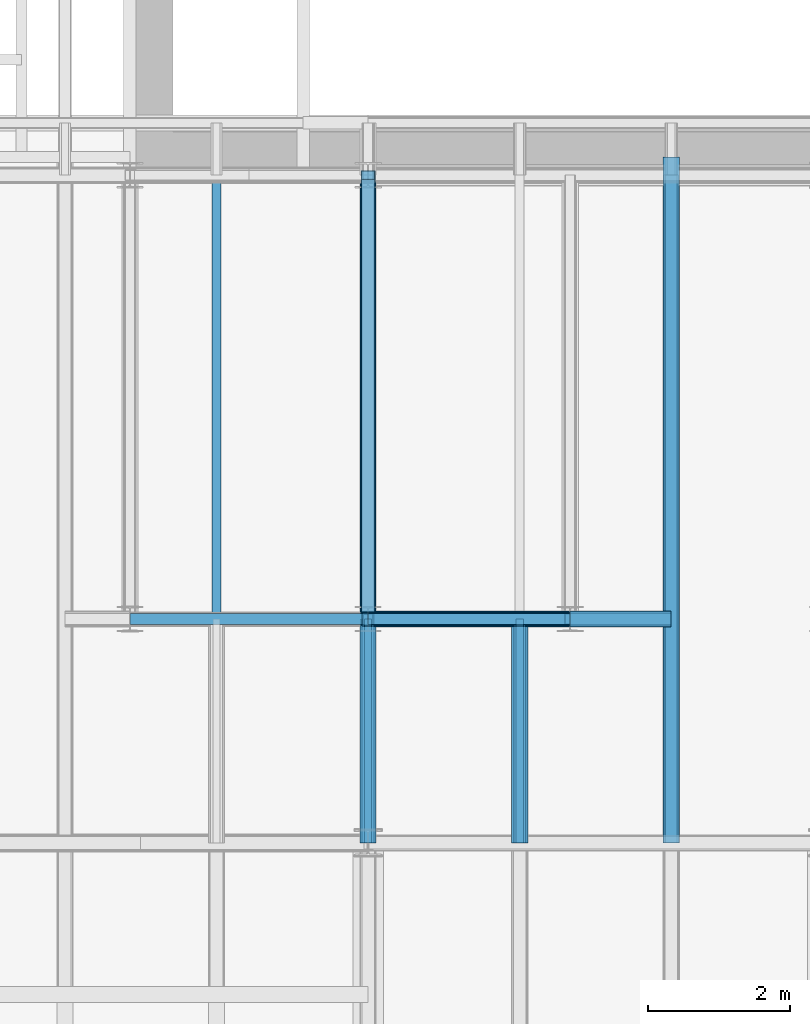
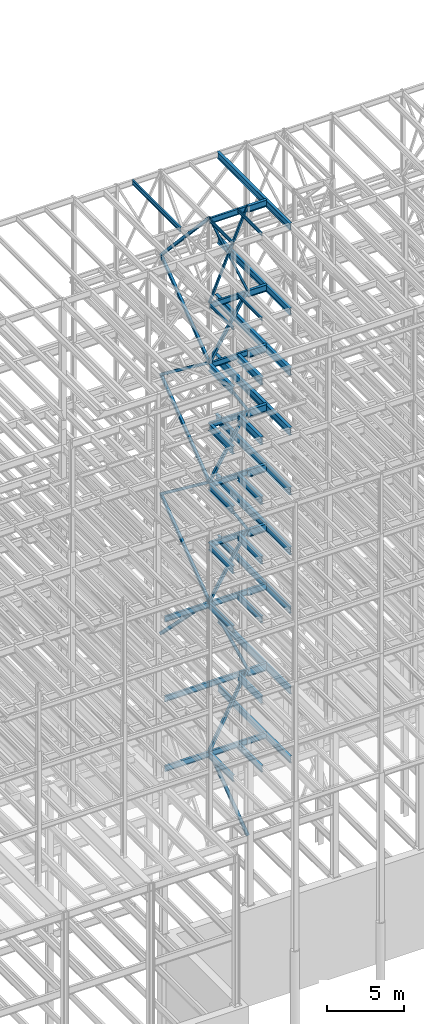
# One storey, part 134 of 150: 65 beams.
"""IFC2X3 building model written with IfcOpenShell, lengths in millimetres."""

import ifcopenshell
import ifcopenshell.guid

model = None  # the IFC model being written
_history = None  # IfcOwnerHistory: only IFC2X3 demands one
_inside = {}  # id of a spatial element -> (the spatial element, [elements in it])
_under = {}  # id of a project, library or spatial element -> (it, [spatial elements below it])
_declared = {}  # id of a project -> (the project, [libraries it declares])
_typed = {}  # id of a type object -> (the type object, [elements of that type])
_made_of = {}  # id of a material, layer set ... -> (it, [elements and type objects made of it])


def new_model(schema):
    """Start an empty IFC model of exactly this schema.

    Asked for "IFC4X3", IfcOpenShell would pick the latest addendum, in which some entities
    have other attributes; the version numbers below select the first issue.
    IFC2X3 requires an IfcOwnerHistory on every rooted entity: one is made here for all.
    """
    global model, _history
    if schema == "IFC4X3":
        model = ifcopenshell.file(schema_version=(4, 3, 0, 0))
    else:
        model = ifcopenshell.file(schema=schema)
    _inside.clear()
    _under.clear()
    _declared.clear()
    _typed.clear()
    _made_of.clear()
    _history = None
    if model.schema == "IFC2X3":
        org = make("IfcOrganization", Name="unknown")
        user = make(
            "IfcPersonAndOrganization",
            ThePerson=make("IfcPerson", FamilyName="unknown"),
            TheOrganization=org,
        )
        app = make(
            "IfcApplication",
            ApplicationDeveloper=org,
            Version="unknown",
            ApplicationFullName="unknown",
            ApplicationIdentifier="unknown",
        )
        _history = make(
            "IfcOwnerHistory",
            OwningUser=user,
            OwningApplication=app,
            ChangeAction="ADDED",
            CreationDate=0,
        )
    return model


def make(cls, **values):
    """One entity of the class cls with the attributes given. An attribute that is None is left unset."""
    return model.create_entity(
        cls, **{name: value for name, value in values.items() if value is not None}
    )


def rooted(cls, **values):
    """An entity with a GlobalId (a new one), such as an element, a storey or a relation."""
    return make(cls, GlobalId=ifcopenshell.guid.new(), OwnerHistory=_history, **values)


def si_unit(unit_type, name, prefix=None):
    """IfcSIUnit, for example si_unit("LENGTHUNIT", "METRE", prefix="MILLI")."""
    return make("IfcSIUnit", UnitType=unit_type, Prefix=prefix, Name=name)


def assignment(units):
    """IfcUnitAssignment: the units of a project."""
    return None if units is None else make("IfcUnitAssignment", Units=units)


def point(xyz):
    """IfcCartesianPoint."""
    return None if xyz is None else make("IfcCartesianPoint", Coordinates=xyz)


def direction(xyz):
    """IfcDirection."""
    return None if xyz is None else make("IfcDirection", DirectionRatios=xyz)


def frame(location, z_axis=None, x_axis=None):
    """IfcAxis2Placement3D, a coordinate frame: its origin and axes. An axis left out is left unset."""
    return make(
        "IfcAxis2Placement3D",
        Location=point(location),
        Axis=direction(z_axis),
        RefDirection=direction(x_axis),
    )


def frame_2d(location, x_axis=None):
    """IfcAxis2Placement2D, a coordinate frame in the plane: its origin and x axis."""
    return make(
        "IfcAxis2Placement2D", Location=point(location), RefDirection=direction(x_axis)
    )


def origin_with_axes():
    """The frame at (0, 0, 0) with the z axis (0, 0, 1) and the x axis (1, 0, 0) written out."""
    return frame((0.0, 0.0, 0.0), z_axis=(0.0, 0.0, 1.0), x_axis=(1.0, 0.0, 0.0))


def origin_2d_with_axis():
    """The frame at (0, 0) in the plane with the x axis (1, 0) written out."""
    return frame_2d((0.0, 0.0), x_axis=(1.0, 0.0))


def place(relative_to, where):
    """IfcLocalPlacement: puts the frame where relative to a parent placement (None: the world)."""
    return make(
        "IfcLocalPlacement", PlacementRelTo=relative_to, RelativePlacement=where
    )


def context(
    kind, dimensions, precision=None, world=None, true_north=None, identifier=None
):
    """IfcGeometricRepresentationContext, for example the 3D "Model" context."""
    return make(
        "IfcGeometricRepresentationContext",
        ContextIdentifier=identifier,
        ContextType=kind,
        CoordinateSpaceDimension=dimensions,
        Precision=precision,
        WorldCoordinateSystem=world,
        TrueNorth=true_north,
    )


def subcontext(parent, identifier, kind, view, scale=None):
    """IfcGeometricRepresentationSubContext, for example "Body" below "Model"."""
    return make(
        "IfcGeometricRepresentationSubContext",
        ContextIdentifier=identifier,
        ContextType=kind,
        ParentContext=parent,
        TargetScale=scale,
        TargetView=view,
    )


def project(units=None, contexts=None):
    """IfcProject with its units and contexts."""
    return rooted(
        "IfcProject",
        Name="project",
        RepresentationContexts=contexts,
        UnitsInContext=assignment(units),
    )


def spatial(cls, under=None, at=None, **own):
    """A site, building, storey or space (cls), placed at a placement, below another one or the project."""
    s = rooted(cls, ObjectPlacement=at, **own)
    if under is not None:
        _under.setdefault(under.id(), (under, []))[1].append(s)
    return s


def profile(cls, at=None, kind="AREA", **sizes):
    """A parametric profile (cls). Its sizes go by their IFC names, for example OverallWidth=200.0."""
    return make(cls, ProfileType=kind, Position=at, **sizes)


def hollow_rectangle(**sizes):
    """IfcRectangleHollowProfileDef."""
    return profile("IfcRectangleHollowProfileDef", **sizes)


def i_section(**sizes):
    """IfcIShapeProfileDef."""
    return profile("IfcIShapeProfileDef", **sizes)


def extrude(swept, where, along, depth):
    """IfcExtrudedAreaSolid: the profile swept, set in the frame where, extruded along a direction by depth."""
    return make(
        "IfcExtrudedAreaSolid",
        SweptArea=swept,
        Position=where,
        ExtrudedDirection=direction(along),
        Depth=depth,
    )


def shape(context_of_items, identifier, shape_type, items):
    """IfcShapeRepresentation: the items that make up one representation, for example the "Body"."""
    return make(
        "IfcShapeRepresentation",
        ContextOfItems=context_of_items,
        RepresentationIdentifier=identifier,
        RepresentationType=shape_type,
        Items=items,
    )


def material(Name=None, Category=None):
    """IfcMaterial."""
    return make("IfcMaterial", Name=Name, Category=Category)


def made_of(thing, what):
    """Note that an element or type object is made of a material, layer set ...; save() writes the relation."""
    if what is not None:
        _made_of.setdefault(what.id(), (what, []))[1].append(thing)
    return thing


def type_object(cls, material=None, **own):
    """A type object (cls), such as IfcWallType, which elements share."""
    return made_of(rooted(cls, **own), material)


def element(
    cls,
    number,
    at=None,
    inside=None,
    cuts=None,
    type_object=None,
    material=None,
    context=None,
    identifier="Body",
    shape_type=None,
    held_by="IfcProductDefinitionShape",
    body=None,
    shapes=None,
    **own,
):
    """One element of the class cls, such as IfcWall. Its Tag is "e" and its number.

    at: its placement. inside: the storey or other place that contains it. cuts: it is an
    opening in that element (IfcRelVoidsElement). A single representation is given by context,
    identifier, shape_type and body (its items); several are given by shapes. held_by: the class
    of the entity that holds the representations. save() writes the other relations.
    """
    e = rooted(cls, Tag="e%d" % number, ObjectPlacement=at, **own)
    if body is not None:
        shapes = [shape(context, identifier, shape_type, body)]
    if shapes is not None:
        e.Representation = make(held_by, Representations=shapes)
    if inside is not None:
        _inside.setdefault(inside.id(), (inside, []))[1].append(e)
    if cuts is not None:
        rooted(
            "IfcRelVoidsElement", RelatingBuildingElement=cuts, RelatedOpeningElement=e
        )
    if type_object is not None:
        _typed.setdefault(type_object.id(), (type_object, []))[1].append(e)
    return made_of(e, material)


def aggregate(whole, parts):
    """IfcRelAggregates: a whole, such as a stair, and the parts it consists of."""
    return rooted("IfcRelAggregates", RelatingObject=whole, RelatedObjects=parts)


def save(model, path):
    """Write the relations noted so far, then the file.

    IfcRelAggregates (storeys below a building ...), IfcRelContainedInSpatialStructure (elements
    in a storey), IfcRelDefinesByType, IfcRelAssociatesMaterial and IfcRelDeclares: one each for
    every whole, place, type object, material and project.
    """
    for whole, parts in _under.values():
        aggregate(whole, parts)
    for where, things in _inside.values():
        rooted(
            "IfcRelContainedInSpatialStructure",
            RelatedElements=things,
            RelatingStructure=where,
        )
    for kind, things in _typed.values():
        rooted("IfcRelDefinesByType", RelatedObjects=things, RelatingType=kind)
    for what, things in _made_of.values():
        rooted("IfcRelAssociatesMaterial", RelatedObjects=things, RelatingMaterial=what)
    for by, libraries in _declared.values():
        rooted("IfcRelDeclares", RelatingContext=by, RelatedDefinitions=libraries)
    model.write(path)


model = new_model("IFC2X3")

# Units and contexts
model_context = context("Model", 3, precision=1e-05, world=origin_with_axes())
body_context = subcontext(model_context, "Body", "Model", "MODEL_VIEW")
ifc_project = project(units=[si_unit("LENGTHUNIT", "METRE", prefix="MILLI"), si_unit("AREAUNIT", "SQUARE_METRE"), si_unit("VOLUMEUNIT", "CUBIC_METRE"), si_unit("MASSUNIT", "GRAM", prefix="KILO"), si_unit("TIMEUNIT", "SECOND"), si_unit("PLANEANGLEUNIT", "RADIAN"), si_unit("SOLIDANGLEUNIT", "STERADIAN"), si_unit("THERMODYNAMICTEMPERATUREUNIT", "DEGREE_CELSIUS"), si_unit("LUMINOUSINTENSITYUNIT", "LUMEN")], contexts=[model_context])

# Site, building, storey
site_placement = place(None, origin_with_axes())
site = spatial("IfcSite", under=ifc_project, at=site_placement, CompositionType="ELEMENT")
building_placement = place(site_placement, origin_with_axes())
building = spatial("IfcBuilding", under=site, at=building_placement, Name="Undefined", CompositionType="ELEMENT")
storey_placement = place(building_placement, origin_with_axes())
storey = spatial("IfcBuildingStorey", under=building, at=storey_placement, Name="Undefined", CompositionType="ELEMENT", Elevation=0.0)

# Beams
ifc_material_1 = material()
beam_type_1 = type_object("IfcBeamType", Name="HSS8X8X3/8", PredefinedType="NOTDEFINED")
beam_1_placement = place(storey_placement, frame((56591.2, 25628.6, 45034.2), z_axis=(0.0, -0.603108242282795, 0.797659355922412), x_axis=(0.0, 0.797659355922412, 0.603108242282795)))
element("IfcBeam", 1, at=beam_1_placement, inside=storey, type_object=beam_type_1, material=ifc_material_1, Name="BEAM", ObjectType="HSS8X8X3/8", context=body_context, shape_type="SweptSolid", body=[
    extrude(hollow_rectangle(XDim=203.2, YDim=203.2, WallThickness=9.525, InnerFilletRadius=9.5249, OuterFilletRadius=19.0499, at=origin_2d_with_axis()), frame((7833.4188347737, 0.0, -8.69684195189813e-13), z_axis=(-1.0, 0.0, 0.0), x_axis=(0.0, -1.0, 0.0)), (0.0, 0.0, 1.0), 7833.4188347737),
])
beam_2_placement = place(storey_placement, frame((56591.2, 31877.0, 40309.8), z_axis=(0.0, 0.603108242282795, 0.797659355922412), x_axis=(0.0, -0.797659355922412, 0.603108242282795)))
element("IfcBeam", 2, at=beam_2_placement, inside=storey, type_object=beam_type_1, material=ifc_material_1, Name="BEAM", ObjectType="HSS8X8X3/8", context=body_context, shape_type="SweptSolid", body=[
    extrude(hollow_rectangle(XDim=203.2, YDim=203.2, WallThickness=9.525, InnerFilletRadius=9.5249, OuterFilletRadius=19.0499, at=origin_2d_with_axis()), frame((7833.41960403484, 0.0, 0.0), z_axis=(-1.0, 0.0, 0.0), x_axis=(0.0, -1.0, 0.0)), (0.0, 0.0, 1.0), 7833.41960403484),
])
beam_3_placement = place(storey_placement, frame((56591.2, 25628.6, 35585.4), z_axis=(0.0, -0.603108242282795, 0.797659355922412), x_axis=(0.0, 0.797659355922412, 0.603108242282795)))
element("IfcBeam", 3, at=beam_3_placement, inside=storey, type_object=beam_type_1, material=ifc_material_1, Name="BEAM", ObjectType="HSS8X8X3/8", context=body_context, shape_type="SweptSolid", body=[
    extrude(hollow_rectangle(XDim=203.2, YDim=203.2, WallThickness=9.525, InnerFilletRadius=9.5249, OuterFilletRadius=19.0499, at=origin_2d_with_axis()), frame((7833.4188347737, 0.0, -8.69684195189813e-13), z_axis=(-1.0, 0.0, 0.0), x_axis=(0.0, -1.0, 0.0)), (0.0, 0.0, 1.0), 7833.41883477371),
])
beam_4_placement = place(storey_placement, frame((56591.2, 25628.6, 54483.0), z_axis=(-0.856679076231124, 0.0, 0.515849745902611), x_axis=(0.51584974590261, 0.0, 0.856679076231124)))
element("IfcBeam", 4, at=beam_4_placement, inside=storey, type_object=beam_type_1, material=ifc_material_1, Name="BEAM", ObjectType="HSS8X8X3/8", context=body_context, shape_type="SweptSolid", body=[
    extrude(hollow_rectangle(XDim=203.2, YDim=203.2, WallThickness=9.525, InnerFilletRadius=9.5249, OuterFilletRadius=19.0499, at=origin_2d_with_axis()), frame((5514.78398489006, -3.63797880709171e-12, 0.0), z_axis=(-1.0, 0.0, 0.0), x_axis=(0.0, -1.0, 0.0)), (0.0, 0.0, 1.0), 5514.78398489007),
])
beam_5_placement = place(storey_placement, frame((59435.9996641932, 25628.6, 49758.5996294296), z_axis=(0.856679076231126, 0.0, 0.515849745902608), x_axis=(-0.515849745902611, 0.0, 0.856679076231124)))
element("IfcBeam", 5, at=beam_5_placement, inside=storey, type_object=beam_type_1, material=ifc_material_1, Name="BEAM", ObjectType="HSS8X8X3/8", context=body_context, shape_type="SweptSolid", body=[
    extrude(hollow_rectangle(XDim=203.2, YDim=203.2, WallThickness=9.525, InnerFilletRadius=9.5249, OuterFilletRadius=19.0499, at=origin_2d_with_axis()), frame((5514.78412912414, -3.63797880709171e-12, 0.0), z_axis=(-1.0, 0.0, 0.0), x_axis=(0.0, -1.0, 0.0)), (0.0, 0.0, 1.0), 5514.78412912414),
])
beam_6_placement = place(storey_placement, frame((56591.2, 25628.6, 45034.2), z_axis=(-0.856679076231124, 0.0, 0.515849745902611), x_axis=(0.51584974590261, 0.0, 0.856679076231124)))
element("IfcBeam", 6, at=beam_6_placement, inside=storey, type_object=beam_type_1, material=ifc_material_1, Name="BEAM", ObjectType="HSS8X8X3/8", context=body_context, shape_type="SweptSolid", body=[
    extrude(hollow_rectangle(XDim=203.2, YDim=203.2, WallThickness=9.525, InnerFilletRadius=9.5249, OuterFilletRadius=19.0499, at=origin_2d_with_axis()), frame((5514.78398489006, -3.63797880709171e-12, 0.0), z_axis=(-1.0, 0.0, 0.0), x_axis=(0.0, -1.0, 0.0)), (0.0, 0.0, 1.0), 5514.78398489008),
])
beam_7_placement = place(storey_placement, frame((59435.9996641932, 25628.6, 40309.7996294296), z_axis=(0.856679076231126, 0.0, 0.515849745902608), x_axis=(-0.515849745902611, 0.0, 0.856679076231124)))
element("IfcBeam", 7, at=beam_7_placement, inside=storey, type_object=beam_type_1, material=ifc_material_1, Name="BEAM", ObjectType="HSS8X8X3/8", context=body_context, shape_type="SweptSolid", body=[
    extrude(hollow_rectangle(XDim=203.2, YDim=203.2, WallThickness=9.525, InnerFilletRadius=9.5249, OuterFilletRadius=19.0499, at=origin_2d_with_axis()), frame((5514.78412912414, -3.63797880709171e-12, 0.0), z_axis=(-1.0, 0.0, 0.0), x_axis=(0.0, -1.0, 0.0)), (0.0, 0.0, 1.0), 5514.78412912414),
])
beam_8_placement = place(storey_placement, frame((56591.2, 25628.6, 35585.4), z_axis=(-0.856679076231124, 0.0, 0.515849745902611), x_axis=(0.51584974590261, 0.0, 0.856679076231124)))
element("IfcBeam", 8, at=beam_8_placement, inside=storey, type_object=beam_type_1, material=ifc_material_1, Name="BEAM", ObjectType="HSS8X8X3/8", context=body_context, shape_type="SweptSolid", body=[
    extrude(hollow_rectangle(XDim=203.2, YDim=203.2, WallThickness=9.525, InnerFilletRadius=9.5249, OuterFilletRadius=19.0499, at=origin_2d_with_axis()), frame((5514.78398489006, -3.63797880709171e-12, 0.0), z_axis=(-1.0, 0.0, 0.0), x_axis=(0.0, -1.0, 0.0)), (0.0, 0.0, 1.0), 5514.78398489007),
])
beam_9_placement = place(storey_placement, frame((59435.9998773698, 25628.6, 29286.1996461044), z_axis=(0.911370591188493, 0.0, 0.4115867411819), x_axis=(-0.411586741181902, 0.0, 0.911370591188492)))
element("IfcBeam", 9, at=beam_9_placement, inside=storey, type_object=beam_type_1, material=ifc_material_1, Name="BEAM", ObjectType="HSS8X8X3/8", context=body_context, shape_type="SweptSolid", body=[
    extrude(hollow_rectangle(XDim=203.2, YDim=203.2, WallThickness=9.525, InnerFilletRadius=9.5249, OuterFilletRadius=19.0499, at=origin_2d_with_axis()), frame((6911.78786138591, 0.0, 3.83681301251766e-13), z_axis=(-1.0, 0.0, 0.0), x_axis=(0.0, -1.0, 0.0)), (0.0, 0.0, 1.0), 6911.78786138592),
])
beam_10_placement = place(storey_placement, frame((56591.2, 25628.6, 23774.4), z_axis=(-0.88862065311074, 0.0, 0.458642927411993), x_axis=(0.458642927411995, 0.0, 0.888620653110738)))
element("IfcBeam", 10, at=beam_10_placement, inside=storey, type_object=beam_type_1, material=ifc_material_1, Name="BEAM", ObjectType="HSS8X8X3/8", context=body_context, shape_type="SweptSolid", body=[
    extrude(hollow_rectangle(XDim=203.2, YDim=203.2, WallThickness=9.525, InnerFilletRadius=9.5249, OuterFilletRadius=19.0499, at=origin_2d_with_axis()), frame((6202.64671571741, 3.63797880709171e-12, 7.27595761418343e-12), z_axis=(-1.0, 0.0, 0.0), x_axis=(0.0, -1.0, 0.0)), (0.0, 0.0, 1.0), 6202.64671571741),
])
ifc_material_2 = material(Name="STEEL/A992")
beam_type_2 = type_object("IfcBeamType", Name="W18X35", PredefinedType="NOTDEFINED")
for number, where, z_axis, x_axis, name in (
    (11, (56591.2, 25628.6, 65687.575), (0.0, 0.0, 1.0), (1.0, 0.0, 0.0), "BEAM"),
    (12, (56591.2, 25628.6, 58981.975), (0.0, 0.0, 1.0), (1.0, 0.0, 0.0), "BEAM"),
    (13, (56591.2, 25628.6, 54257.575), (0.0, 0.0, 1.0), (1.0, 0.0, 0.0), "BEAM"),
    (14, (56591.2, 25628.6, 49533.175), (0.0, 0.0, 1.0), (1.0, 0.0, 0.0), "BEAM"),
    (15, (56591.2, 25628.6, 44808.775), (0.0, 0.0, 1.0), (1.0, 0.0, 0.0), "BEAM"),
    (16, (56591.2, 25628.6, 40084.375), (0.0, 0.0, 1.0), (1.0, 0.0, 0.0), "BEAM"),
    (17, (56591.2, 25628.6, 35359.975), (0.0, 0.0, 1.0), (1.0, 0.0, 0.0), "BEAM"),
):
    element("IfcBeam", number, at=place(storey_placement, frame(where, z_axis=z_axis, x_axis=x_axis)), inside=storey, type_object=beam_type_2, material=ifc_material_2, Name=name, ObjectType="W18X35", context=body_context, shape_type="SweptSolid", body=[
        extrude(i_section(OverallWidth=152.4, OverallDepth=450.85, WebThickness=7.9375, FlangeThickness=10.795, FilletRadius=17.78, at=origin_2d_with_axis()), frame((2844.8, 0.0, 0.0), z_axis=(-1.0, 0.0, 0.0), x_axis=(0.0, -1.0, 0.0)), (0.0, 0.0, 1.0), 2844.8),
    ])
beam_11_placement = place(storey_placement, frame((53238.4, 25628.6, 35359.975), z_axis=(0.0, 0.0, 1.0), x_axis=(1.0, 0.0, 0.0)))
element("IfcBeam", 18, at=beam_11_placement, inside=storey, type_object=beam_type_2, material=ifc_material_2, Name="BEAM", ObjectType="W18X35", context=body_context, shape_type="SweptSolid", body=[
    extrude(i_section(OverallWidth=152.4, OverallDepth=450.85, WebThickness=7.9375, FlangeThickness=10.795, FilletRadius=17.78, at=origin_2d_with_axis()), frame((3352.8, 0.0, 0.0), z_axis=(-1.0, 0.0, 0.0), x_axis=(0.0, -1.0, 0.0)), (0.0, 0.0, 1.0), 3352.8),
])
beam_12_placement = place(storey_placement, frame((56591.2, 25628.6, 29060.775), z_axis=(0.0, 0.0, 1.0), x_axis=(1.0, 0.0, 0.0)))
element("IfcBeam", 19, at=beam_12_placement, inside=storey, type_object=beam_type_2, material=ifc_material_2, Name="BEAM", ObjectType="W18X35", context=body_context, shape_type="SweptSolid", body=[
    extrude(i_section(OverallWidth=152.4, OverallDepth=450.85, WebThickness=7.9375, FlangeThickness=10.795, FilletRadius=17.78, at=origin_2d_with_axis()), frame((2844.8, 0.0, 0.0), z_axis=(-1.0, 0.0, 0.0), x_axis=(0.0, -1.0, 0.0)), (0.0, 0.0, 1.0), 2844.8),
])
beam_13_placement = place(storey_placement, frame((53238.4, 25628.6, 29060.775), z_axis=(0.0, 0.0, 1.0), x_axis=(1.0, 0.0, 0.0)))
element("IfcBeam", 20, at=beam_13_placement, inside=storey, type_object=beam_type_2, material=ifc_material_2, Name="BEAM", ObjectType="W18X35", context=body_context, shape_type="SweptSolid", body=[
    extrude(i_section(OverallWidth=152.4, OverallDepth=450.85, WebThickness=7.9375, FlangeThickness=10.795, FilletRadius=17.78, at=origin_2d_with_axis()), frame((3352.8, 0.0, 0.0), z_axis=(-1.0, 0.0, 0.0), x_axis=(0.0, -1.0, 0.0)), (0.0, 0.0, 1.0), 3352.8),
])
beam_14_placement = place(storey_placement, frame((59436.0, 25628.6, 23548.975), z_axis=(0.0, 0.0, 1.0), x_axis=(1.0, 0.0, 0.0)))
element("IfcBeam", 21, at=beam_14_placement, inside=storey, type_object=beam_type_2, material=ifc_material_2, Name="BEAM", ObjectType="W18X35", context=body_context, shape_type="SweptSolid", body=[
    extrude(i_section(OverallWidth=152.4, OverallDepth=450.85, WebThickness=7.9375, FlangeThickness=10.795, FilletRadius=17.78, at=origin_2d_with_axis()), frame((1422.39999999999, 0.0, 0.0), z_axis=(-1.0, 0.0, 0.0), x_axis=(0.0, -1.0, 0.0)), (0.0, 0.0, 1.0), 1422.4),
])
beam_15_placement = place(storey_placement, frame((56591.2, 25628.6, 23548.975), z_axis=(0.0, 0.0, 1.0), x_axis=(1.0, 0.0, 0.0)))
element("IfcBeam", 22, at=beam_15_placement, inside=storey, type_object=beam_type_2, material=ifc_material_2, Name="BEAM", ObjectType="W18X35", context=body_context, shape_type="SweptSolid", body=[
    extrude(i_section(OverallWidth=152.4, OverallDepth=450.85, WebThickness=7.9375, FlangeThickness=10.795, FilletRadius=17.78, at=origin_2d_with_axis()), frame((2844.8, 0.0, 0.0), z_axis=(-1.0, 0.0, 0.0), x_axis=(0.0, -1.0, 0.0)), (0.0, 0.0, 1.0), 2844.8),
])
beam_16_placement = place(storey_placement, frame((53238.4, 25628.6, 23548.975), z_axis=(0.0, 0.0, 1.0), x_axis=(1.0, 0.0, 0.0)))
element("IfcBeam", 23, at=beam_16_placement, inside=storey, type_object=beam_type_2, material=ifc_material_2, Name="BEAM", ObjectType="W18X35", context=body_context, shape_type="SweptSolid", body=[
    extrude(i_section(OverallWidth=152.4, OverallDepth=450.85, WebThickness=7.9375, FlangeThickness=10.795, FilletRadius=17.78, at=origin_2d_with_axis()), frame((3352.8, 0.0, 0.0), z_axis=(-1.0, 0.0, 0.0), x_axis=(0.0, -1.0, 0.0)), (0.0, 0.0, 1.0), 3352.8),
])
beam_type_3 = type_object("IfcBeamType", Name="HSS8X8X1/4", PredefinedType="NOTDEFINED")
beam_17_placement = place(storey_placement, frame((56591.2, 31877.0, 59207.4), z_axis=(0.0, 0.73160793181113, 0.681725629642191), x_axis=(0.0, -0.681725629642191, 0.731607931811129)))
element("IfcBeam", 24, at=beam_17_placement, inside=storey, type_object=beam_type_3, material=ifc_material_1, Name="BEAM", ObjectType="HSS8X8X1/4", context=body_context, shape_type="SweptSolid", body=[
    extrude(hollow_rectangle(XDim=203.2, YDim=203.2, WallThickness=6.35, InnerFilletRadius=6.3499, OuterFilletRadius=12.6999, at=origin_2d_with_axis()), frame((9165.56457180898, 0.0, -7.27595761418343e-12), z_axis=(-1.0, 0.0, 0.0), x_axis=(0.0, -1.0, 0.0)), (0.0, 0.0, 1.0), 9165.56457180899),
])
for number, where, z_axis, x_axis, name in (
    (25, (56591.2, 25628.6, 54483.0), (0.0, -0.603108242282795, 0.797659355922412), (0.0, 0.797659355922412, 0.603108242282795), "BEAM"),
    (26, (56591.2, 31877.0, 49758.6), (0.0, 0.603108242282795, 0.797659355922412), (0.0, -0.797659355922412, 0.603108242282795), "BEAM"),
):
    element("IfcBeam", number, at=place(storey_placement, frame(where, z_axis=z_axis, x_axis=x_axis)), inside=storey, type_object=beam_type_3, material=ifc_material_1, Name=name, ObjectType="HSS8X8X1/4", context=body_context, shape_type="SweptSolid", body=[
        extrude(hollow_rectangle(XDim=203.2, YDim=203.2, WallThickness=6.35, InnerFilletRadius=6.3499, OuterFilletRadius=12.6999, at=origin_2d_with_axis()), frame((7833.41929938644, 0.0, 0.0), z_axis=(-1.0, 0.0, 0.0), x_axis=(0.0, -1.0, 0.0)), (0.0, 0.0, 1.0), 7833.41929938644),
    ])
beam_type_4 = type_object("IfcBeamType", Name="HSS6X6X1/4", PredefinedType="NOTDEFINED")
beam_18_placement = place(storey_placement, frame((56591.2, 25628.6, 59207.4), z_axis=(-0.920581786233234, 0.0, 0.390549836583795), x_axis=(0.390549836583795, 0.0, 0.920581786233234)))
element("IfcBeam", 27, at=beam_18_placement, inside=storey, type_object=beam_type_4, material=ifc_material_1, Name="BEAM", ObjectType="HSS6X6X1/4", context=body_context, shape_type="SweptSolid", body=[
    extrude(hollow_rectangle(XDim=152.4, YDim=152.4, WallThickness=6.35, InnerFilletRadius=6.3499, OuterFilletRadius=12.6999, at=origin_2d_with_axis()), frame((7284.08940087915, 0.0, -4.04348188314205e-13), z_axis=(-1.0, 0.0, 0.0), x_axis=(0.0, -1.0, 0.0)), (0.0, 0.0, 1.0), 7284.08940087915),
])
beam_19_placement = place(storey_placement, frame((59435.9996641932, 25628.6, 59207.3996294296), z_axis=(0.920581786233233, 0.0, 0.390549836583797), x_axis=(-0.390549836583795, 0.0, 0.920581786233234)))
element("IfcBeam", 28, at=beam_19_placement, inside=storey, type_object=beam_type_4, material=ifc_material_1, Name="BEAM", ObjectType="HSS6X6X1/4", context=body_context, shape_type="SweptSolid", body=[
    extrude(hollow_rectangle(XDim=152.4, YDim=152.4, WallThickness=6.35, InnerFilletRadius=6.3499, OuterFilletRadius=12.6999, at=origin_2d_with_axis()), frame((7284.08961087023, 0.0, 0.0), z_axis=(-1.0, 0.0, 0.0), x_axis=(0.0, -1.0, 0.0)), (0.0, 0.0, 1.0), 7284.08961087023),
])
beam_type_5 = type_object("IfcBeamType", Name="HSS9X9X1/2", PredefinedType="NOTDEFINED")
beam_20_placement = place(storey_placement, frame((56591.2, 31877.0, 29286.2), z_axis=(0.0, 0.709963736329935, 0.704238236036952), x_axis=(0.0, -0.704238236036953, 0.709963736329935)))
element("IfcBeam", 29, at=beam_20_placement, inside=storey, type_object=beam_type_5, material=ifc_material_1, Name="BEAM", ObjectType="HSS9X9X1/2", context=body_context, shape_type="SweptSolid", body=[
    extrude(hollow_rectangle(XDim=228.6, YDim=228.6, WallThickness=12.7, InnerFilletRadius=12.6999, OuterFilletRadius=25.3999, at=origin_2d_with_axis()), frame((8872.56576194282, 0.0, 0.0), z_axis=(-1.0, 0.0, 0.0), x_axis=(0.0, -1.0, 0.0)), (0.0, 0.0, 1.0), 8872.56576194282),
])
beam_21_placement = place(storey_placement, frame((59436.0, 25628.6, 16154.4), z_axis=(0.936841534387209, 0.0, 0.349754112837891), x_axis=(-0.349754112837889, 0.0, 0.936841534387209)))
element("IfcBeam", 30, at=beam_21_placement, inside=storey, type_object=beam_type_5, material=ifc_material_1, Name="BEAM", ObjectType="HSS9X9X1/2", context=body_context, shape_type="SweptSolid", body=[
    extrude(hollow_rectangle(XDim=228.6, YDim=228.6, WallThickness=12.7, InnerFilletRadius=12.6999, OuterFilletRadius=25.3999, at=origin_2d_with_axis()), frame((8133.71278089504, 3.63797880709171e-12, 0.0), z_axis=(-1.0, 0.0, 0.0), x_axis=(0.0, -1.0, 0.0)), (0.0, 0.0, 1.0), 8133.71278089504),
])
beam_type_6 = type_object("IfcBeamType", Name="W24X68", PredefinedType="NOTDEFINED")
beam_22_placement = place(storey_placement, frame((59436.0, 25628.6, 54181.375), z_axis=(0.0, 0.0, 1.0), x_axis=(1.0, 0.0, 0.0)))
element("IfcBeam", 31, at=beam_22_placement, inside=storey, type_object=beam_type_6, material=ifc_material_2, Name="BEAM", ObjectType="W24X68", context=body_context, shape_type="SweptSolid", body=[
    extrude(i_section(OverallWidth=227.838, OverallDepth=603.25, WebThickness=11.1125, FlangeThickness=14.859, FilletRadius=23.2409, at=origin_2d_with_axis()), frame((1422.39999999999, 0.0, 0.0), z_axis=(-1.0, 0.0, 0.0), x_axis=(0.0, -1.0, 0.0)), (0.0, 0.0, 1.0), 1422.39999999999),
])
beam_23_placement = place(storey_placement, frame((60858.4, 22479.0, 54181.375), z_axis=(0.0, 0.0, 1.0), x_axis=(0.0, 1.0, 0.0)))
element("IfcBeam", 32, at=beam_23_placement, inside=storey, type_object=beam_type_6, material=ifc_material_2, Name="BEAM", ObjectType="W24X68", context=body_context, shape_type="SweptSolid", body=[
    extrude(i_section(OverallWidth=227.838, OverallDepth=603.25, WebThickness=11.1125, FlangeThickness=14.859, FilletRadius=23.2409, at=origin_2d_with_axis()), frame((9652.0, 0.0, 0.0), z_axis=(-1.0, 0.0, 0.0), x_axis=(0.0, -1.0, 0.0)), (0.0, 0.0, 1.0), 9652.0),
])
for number, where, z_axis, x_axis, name in (
    (33, (56591.2, 22479.0, 54181.375), (0.0, 0.0, 1.0), (0.0, 1.0, 0.0), "BEAM"),
    (34, (58724.8, 22479.0, 54181.375), (0.0, 0.0, 1.0), (0.0, 1.0, 0.0), "BEAM"),
):
    element("IfcBeam", number, at=place(storey_placement, frame(where, z_axis=z_axis, x_axis=x_axis)), inside=storey, type_object=beam_type_6, material=ifc_material_2, Name=name, ObjectType="W24X68", context=body_context, shape_type="SweptSolid", body=[
        extrude(i_section(OverallWidth=227.838, OverallDepth=603.25, WebThickness=11.1125, FlangeThickness=14.859, FilletRadius=23.2409, at=origin_2d_with_axis()), frame((3149.59999999999, 0.0, 0.0), z_axis=(-1.0, 0.0, 0.0), x_axis=(0.0, -1.0, 0.0)), (0.0, 0.0, 1.0), 3149.6),
    ])
beam_24_placement = place(storey_placement, frame((59436.0, 25628.6, 49456.975), z_axis=(0.0, 0.0, 1.0), x_axis=(1.0, 0.0, 0.0)))
element("IfcBeam", 35, at=beam_24_placement, inside=storey, type_object=beam_type_6, material=ifc_material_2, Name="BEAM", ObjectType="W24X68", context=body_context, shape_type="SweptSolid", body=[
    extrude(i_section(OverallWidth=227.838, OverallDepth=603.25, WebThickness=11.1125, FlangeThickness=14.859, FilletRadius=23.2409, at=origin_2d_with_axis()), frame((1422.39999999999, 0.0, 0.0), z_axis=(-1.0, 0.0, 0.0), x_axis=(0.0, -1.0, 0.0)), (0.0, 0.0, 1.0), 1422.39999999999),
])
beam_25_placement = place(storey_placement, frame((60858.4, 22479.0, 49456.975), z_axis=(0.0, 0.0, 1.0), x_axis=(0.0, 1.0, 0.0)))
element("IfcBeam", 36, at=beam_25_placement, inside=storey, type_object=beam_type_6, material=ifc_material_2, Name="BEAM", ObjectType="W24X68", context=body_context, shape_type="SweptSolid", body=[
    extrude(i_section(OverallWidth=227.838, OverallDepth=603.25, WebThickness=11.1125, FlangeThickness=14.859, FilletRadius=23.2409, at=origin_2d_with_axis()), frame((9652.0, 0.0, 0.0), z_axis=(-1.0, 0.0, 0.0), x_axis=(0.0, -1.0, 0.0)), (0.0, 0.0, 1.0), 9652.0),
])
for number, where, z_axis, x_axis, name in (
    (37, (56591.2, 22479.0, 49456.975), (0.0, 0.0, 1.0), (0.0, 1.0, 0.0), "BEAM"),
    (38, (58724.8, 22479.0, 49456.975), (0.0, 0.0, 1.0), (0.0, 1.0, 0.0), "BEAM"),
):
    element("IfcBeam", number, at=place(storey_placement, frame(where, z_axis=z_axis, x_axis=x_axis)), inside=storey, type_object=beam_type_6, material=ifc_material_2, Name=name, ObjectType="W24X68", context=body_context, shape_type="SweptSolid", body=[
        extrude(i_section(OverallWidth=227.838, OverallDepth=603.25, WebThickness=11.1125, FlangeThickness=14.859, FilletRadius=23.2409, at=origin_2d_with_axis()), frame((3149.59999999999, 0.0, 0.0), z_axis=(-1.0, 0.0, 0.0), x_axis=(0.0, -1.0, 0.0)), (0.0, 0.0, 1.0), 3149.6),
    ])
beam_26_placement = place(storey_placement, frame((59436.0, 25628.6, 44732.575), z_axis=(0.0, 0.0, 1.0), x_axis=(1.0, 0.0, 0.0)))
element("IfcBeam", 39, at=beam_26_placement, inside=storey, type_object=beam_type_6, material=ifc_material_2, Name="BEAM", ObjectType="W24X68", context=body_context, shape_type="SweptSolid", body=[
    extrude(i_section(OverallWidth=227.838, OverallDepth=603.25, WebThickness=11.1125, FlangeThickness=14.859, FilletRadius=23.2409, at=origin_2d_with_axis()), frame((1422.39999999999, 0.0, 0.0), z_axis=(-1.0, 0.0, 0.0), x_axis=(0.0, -1.0, 0.0)), (0.0, 0.0, 1.0), 1422.39999999999),
])
beam_27_placement = place(storey_placement, frame((60858.4, 22479.0, 44732.575), z_axis=(0.0, 0.0, 1.0), x_axis=(0.0, 1.0, 0.0)))
element("IfcBeam", 40, at=beam_27_placement, inside=storey, type_object=beam_type_6, material=ifc_material_2, Name="BEAM", ObjectType="W24X68", context=body_context, shape_type="SweptSolid", body=[
    extrude(i_section(OverallWidth=227.838, OverallDepth=603.25, WebThickness=11.1125, FlangeThickness=14.859, FilletRadius=23.2409, at=origin_2d_with_axis()), frame((9652.0, 0.0, 0.0), z_axis=(-1.0, 0.0, 0.0), x_axis=(0.0, -1.0, 0.0)), (0.0, 0.0, 1.0), 9652.0),
])
for number, where, z_axis, x_axis, name in (
    (41, (56591.2, 22479.0, 44732.575), (0.0, 0.0, 1.0), (0.0, 1.0, 0.0), "BEAM"),
    (42, (58724.8, 22479.0, 44732.575), (0.0, 0.0, 1.0), (0.0, 1.0, 0.0), "BEAM"),
):
    element("IfcBeam", number, at=place(storey_placement, frame(where, z_axis=z_axis, x_axis=x_axis)), inside=storey, type_object=beam_type_6, material=ifc_material_2, Name=name, ObjectType="W24X68", context=body_context, shape_type="SweptSolid", body=[
        extrude(i_section(OverallWidth=227.838, OverallDepth=603.25, WebThickness=11.1125, FlangeThickness=14.859, FilletRadius=23.2409, at=origin_2d_with_axis()), frame((3149.59999999999, 0.0, 0.0), z_axis=(-1.0, 0.0, 0.0), x_axis=(0.0, -1.0, 0.0)), (0.0, 0.0, 1.0), 3149.6),
    ])
beam_28_placement = place(storey_placement, frame((59436.0, 25628.6, 40008.175), z_axis=(0.0, 0.0, 1.0), x_axis=(1.0, 0.0, 0.0)))
element("IfcBeam", 43, at=beam_28_placement, inside=storey, type_object=beam_type_6, material=ifc_material_2, Name="BEAM", ObjectType="W24X68", context=body_context, shape_type="SweptSolid", body=[
    extrude(i_section(OverallWidth=227.838, OverallDepth=603.25, WebThickness=11.1125, FlangeThickness=14.859, FilletRadius=23.2409, at=origin_2d_with_axis()), frame((1422.39999999999, 0.0, 0.0), z_axis=(-1.0, 0.0, 0.0), x_axis=(0.0, -1.0, 0.0)), (0.0, 0.0, 1.0), 1422.39999999999),
])
beam_29_placement = place(storey_placement, frame((60858.4, 22479.0, 40008.175), z_axis=(0.0, 0.0, 1.0), x_axis=(0.0, 1.0, 0.0)))
element("IfcBeam", 44, at=beam_29_placement, inside=storey, type_object=beam_type_6, material=ifc_material_2, Name="BEAM", ObjectType="W24X68", context=body_context, shape_type="SweptSolid", body=[
    extrude(i_section(OverallWidth=227.838, OverallDepth=603.25, WebThickness=11.1125, FlangeThickness=14.859, FilletRadius=23.2409, at=origin_2d_with_axis()), frame((9652.0, 0.0, 0.0), z_axis=(-1.0, 0.0, 0.0), x_axis=(0.0, -1.0, 0.0)), (0.0, 0.0, 1.0), 9652.0),
])
for number, where, z_axis, x_axis, name in (
    (45, (56591.2, 22479.0, 40008.175), (0.0, 0.0, 1.0), (0.0, 1.0, 0.0), "BEAM"),
    (46, (58724.8, 22479.0, 40008.175), (0.0, 0.0, 1.0), (0.0, 1.0, 0.0), "BEAM"),
):
    element("IfcBeam", number, at=place(storey_placement, frame(where, z_axis=z_axis, x_axis=x_axis)), inside=storey, type_object=beam_type_6, material=ifc_material_2, Name=name, ObjectType="W24X68", context=body_context, shape_type="SweptSolid", body=[
        extrude(i_section(OverallWidth=227.838, OverallDepth=603.25, WebThickness=11.1125, FlangeThickness=14.859, FilletRadius=23.2409, at=origin_2d_with_axis()), frame((3149.59999999999, 0.0, 0.0), z_axis=(-1.0, 0.0, 0.0), x_axis=(0.0, -1.0, 0.0)), (0.0, 0.0, 1.0), 3149.6),
    ])
beam_type_7 = type_object("IfcBeamType", Name="W14X22", PredefinedType="NOTDEFINED")
beam_30_placement = place(storey_placement, frame((54457.6, 25628.6, 65738.375), z_axis=(0.0, 0.0, 1.0), x_axis=(0.0, 1.0, 0.0)))
element("IfcBeam", 47, at=beam_30_placement, inside=storey, type_object=beam_type_7, material=ifc_material_2, Name="BEAM", ObjectType="W14X22", context=body_context, shape_type="SweptSolid", body=[
    extrude(i_section(OverallWidth=127.0, OverallDepth=349.25, WebThickness=6.3499, FlangeThickness=8.509, FilletRadius=18.4785, at=origin_2d_with_axis()), frame((6248.40000000001, 0.0, 0.0), z_axis=(-1.0, 0.0, 0.0), x_axis=(0.0, -1.0, 0.0)), (0.0, 0.0, 1.0), 6248.40000000001),
])
beam_type_8 = type_object("IfcBeamType", Name="W21X55", PredefinedType="NOTDEFINED")
beam_31_placement = place(storey_placement, frame((59436.0, 25628.6, 65649.475), z_axis=(0.0, 0.0, 1.0), x_axis=(1.0, 0.0, 0.0)))
element("IfcBeam", 48, at=beam_31_placement, inside=storey, type_object=beam_type_8, material=ifc_material_2, Name="BEAM", ObjectType="W21X55", context=body_context, shape_type="SweptSolid", body=[
    extrude(i_section(OverallWidth=208.788, OverallDepth=527.05, WebThickness=9.5, FlangeThickness=13.2588, FilletRadius=16.8624, at=origin_2d_with_axis()), frame((1422.39999999999, 0.0, 0.0), z_axis=(-1.0, 0.0, 0.0), x_axis=(0.0, -1.0, 0.0)), (0.0, 0.0, 1.0), 1422.39999999999),
])
beam_32_placement = place(storey_placement, frame((60858.4, 22479.0, 65649.475), z_axis=(0.0, 0.0, 1.0), x_axis=(0.0, 1.0, 0.0)))
element("IfcBeam", 49, at=beam_32_placement, inside=storey, type_object=beam_type_8, material=ifc_material_2, Name="BEAM", ObjectType="W21X55", context=body_context, shape_type="SweptSolid", body=[
    extrude(i_section(OverallWidth=208.788, OverallDepth=527.05, WebThickness=9.5, FlangeThickness=13.2588, FilletRadius=16.8624, at=origin_2d_with_axis()), frame((9398.0, 0.0, 0.0), z_axis=(-1.0, 0.0, 0.0), x_axis=(0.0, -1.0, 0.0)), (0.0, 0.0, 1.0), 9398.0),
])
beam_33_placement = place(storey_placement, frame((59436.0, 25628.6, 58943.875), z_axis=(0.0, 0.0, 1.0), x_axis=(1.0, 0.0, 0.0)))
element("IfcBeam", 50, at=beam_33_placement, inside=storey, type_object=beam_type_8, material=ifc_material_2, Name="BEAM", ObjectType="W21X55", context=body_context, shape_type="SweptSolid", body=[
    extrude(i_section(OverallWidth=208.788, OverallDepth=527.05, WebThickness=9.5, FlangeThickness=13.2588, FilletRadius=16.8624, at=origin_2d_with_axis()), frame((1422.39999999999, 0.0, 0.0), z_axis=(-1.0, 0.0, 0.0), x_axis=(0.0, -1.0, 0.0)), (0.0, 0.0, 1.0), 1422.39999999999),
])
beam_34_placement = place(storey_placement, frame((60858.4, 22479.0, 58943.875), z_axis=(0.0, 0.0, 1.0), x_axis=(0.0, 1.0, 0.0)))
element("IfcBeam", 51, at=beam_34_placement, inside=storey, type_object=beam_type_8, material=ifc_material_2, Name="BEAM", ObjectType="W21X55", context=body_context, shape_type="SweptSolid", body=[
    extrude(i_section(OverallWidth=208.788, OverallDepth=527.05, WebThickness=9.5, FlangeThickness=13.2588, FilletRadius=16.8624, at=origin_2d_with_axis()), frame((9398.0, 0.0, 0.0), z_axis=(-1.0, 0.0, 0.0), x_axis=(0.0, -1.0, 0.0)), (0.0, 0.0, 1.0), 9398.0),
])
beam_type_9 = type_object("IfcBeamType", Name="W10X15", PredefinedType="NOTDEFINED")
for number, where, z_axis, x_axis, name in (
    (52, (56591.2, 22479.0, 65786.0), (0.0, 0.0, 1.0), (0.0, 1.0, 0.0), "BEAM"),
    (53, (58724.8, 22479.0, 65786.0), (0.0, 0.0, 1.0), (0.0, 1.0, 0.0), "BEAM"),
    (54, (56591.2, 22479.0, 59080.4), (0.0, 0.0, 1.0), (0.0, 1.0, 0.0), "BEAM"),
    (55, (58724.8, 22479.0, 59080.4), (0.0, 0.0, 1.0), (0.0, 1.0, 0.0), "BEAM"),
):
    element("IfcBeam", number, at=place(storey_placement, frame(where, z_axis=z_axis, x_axis=x_axis)), inside=storey, type_object=beam_type_9, material=ifc_material_2, Name=name, ObjectType="W10X15", context=body_context, shape_type="SweptSolid", body=[
        extrude(i_section(OverallWidth=101.6, OverallDepth=254.0, WebThickness=6.3499, FlangeThickness=6.858, FilletRadius=13.7795, at=origin_2d_with_axis()), frame((3149.59999999999, 0.0, 0.0), z_axis=(-1.0, 0.0, 0.0), x_axis=(0.0, -1.0, 0.0)), (0.0, 0.0, 1.0), 3149.6),
    ])
beam_type_10 = type_object("IfcBeamType", Name="W24X55", PredefinedType="NOTDEFINED")
beam_35_placement = place(storey_placement, frame((59436.0, 25628.6, 28986.1625), z_axis=(0.0, 0.0, 1.0), x_axis=(1.0, 0.0, 0.0)))
element("IfcBeam", 56, at=beam_35_placement, inside=storey, type_object=beam_type_10, material=ifc_material_2, Name="BEAM", ObjectType="W24X55", context=body_context, shape_type="SweptSolid", body=[
    extrude(i_section(OverallWidth=178.054, OverallDepth=600.075, WebThickness=9.5249, FlangeThickness=12.827, FilletRadius=23.6854, at=origin_2d_with_axis()), frame((1422.39999999999, 0.0, 0.0), z_axis=(-1.0, 0.0, 0.0), x_axis=(0.0, -1.0, 0.0)), (0.0, 0.0, 1.0), 1422.39999999999),
])
beam_36_placement = place(storey_placement, frame((60858.4, 22479.0, 28986.1625), z_axis=(0.0, 0.0, 1.0), x_axis=(0.0, 1.0, 0.0)))
element("IfcBeam", 57, at=beam_36_placement, inside=storey, type_object=beam_type_10, material=ifc_material_2, Name="BEAM", ObjectType="W24X55", context=body_context, shape_type="SweptSolid", body=[
    extrude(i_section(OverallWidth=178.054, OverallDepth=600.075, WebThickness=9.5249, FlangeThickness=12.827, FilletRadius=23.6854, at=origin_2d_with_axis()), frame((9398.0, 0.0, 0.0), z_axis=(-1.0, 0.0, 0.0), x_axis=(0.0, -1.0, 0.0)), (0.0, 0.0, 1.0), 9398.00000000001),
])
beam_37_placement = place(storey_placement, frame((58724.8, 22479.0, 28986.1625), z_axis=(0.0, 0.0, 1.0), x_axis=(0.0, 1.0, 0.0)))
element("IfcBeam", 58, at=beam_37_placement, inside=storey, type_object=beam_type_10, material=ifc_material_2, Name="BEAM", ObjectType="W24X55", context=body_context, shape_type="SweptSolid", body=[
    extrude(i_section(OverallWidth=178.054, OverallDepth=600.075, WebThickness=9.5249, FlangeThickness=12.827, FilletRadius=23.6854, at=origin_2d_with_axis()), frame((3149.59999999999, 0.0, 0.0), z_axis=(-1.0, 0.0, 0.0), x_axis=(0.0, -1.0, 0.0)), (0.0, 0.0, 1.0), 3149.59999999999),
])
beam_type_11 = type_object("IfcBeamType", Name="W21X44", PredefinedType="NOTDEFINED")
beam_38_placement = place(storey_placement, frame((59436.0, 25628.6, 35323.4625), z_axis=(0.0, 0.0, 1.0), x_axis=(1.0, 0.0, 0.0)))
element("IfcBeam", 59, at=beam_38_placement, inside=storey, type_object=beam_type_11, material=ifc_material_2, Name="BEAM", ObjectType="W21X44", context=body_context, shape_type="SweptSolid", body=[
    extrude(i_section(OverallWidth=165.1, OverallDepth=523.875, WebThickness=9.5249, FlangeThickness=11.43, FilletRadius=17.145, at=origin_2d_with_axis()), frame((1422.39999999999, 0.0, 0.0), z_axis=(-1.0, 0.0, 0.0), x_axis=(0.0, -1.0, 0.0)), (0.0, 0.0, 1.0), 1422.4),
])
beam_39_placement = place(storey_placement, frame((56591.2, 22479.0, 35323.4625), z_axis=(0.0, 0.0, 1.0), x_axis=(0.0, 1.0, 0.0)))
element("IfcBeam", 60, at=beam_39_placement, inside=storey, type_object=beam_type_11, material=ifc_material_2, Name="BEAM", ObjectType="W21X44", context=body_context, shape_type="SweptSolid", body=[
    extrude(i_section(OverallWidth=165.1, OverallDepth=523.875, WebThickness=9.5249, FlangeThickness=11.43, FilletRadius=17.145, at=origin_2d_with_axis()), frame((3149.59999999999, 0.0, 0.0), z_axis=(-1.0, 0.0, 0.0), x_axis=(0.0, -1.0, 0.0)), (0.0, 0.0, 1.0), 3149.6),
])
beam_40_placement = place(storey_placement, frame((60858.4, 22479.0, 35323.4625), z_axis=(0.0, 0.0, 1.0), x_axis=(0.0, 1.0, 0.0)))
element("IfcBeam", 61, at=beam_40_placement, inside=storey, type_object=beam_type_11, material=ifc_material_2, Name="BEAM", ObjectType="W21X44", context=body_context, shape_type="SweptSolid", body=[
    extrude(i_section(OverallWidth=165.1, OverallDepth=523.875, WebThickness=9.5249, FlangeThickness=11.43, FilletRadius=17.145, at=origin_2d_with_axis()), frame((9398.0, 0.0, 0.0), z_axis=(-1.0, 0.0, 0.0), x_axis=(0.0, -1.0, 0.0)), (0.0, 0.0, 1.0), 9398.0),
])
beam_41_placement = place(storey_placement, frame((58724.8, 22479.0, 35323.4625), z_axis=(0.0, 0.0, 1.0), x_axis=(0.0, 1.0, 0.0)))
element("IfcBeam", 62, at=beam_41_placement, inside=storey, type_object=beam_type_11, material=ifc_material_2, Name="BEAM", ObjectType="W21X44", context=body_context, shape_type="SweptSolid", body=[
    extrude(i_section(OverallWidth=165.1, OverallDepth=523.875, WebThickness=9.5249, FlangeThickness=11.43, FilletRadius=17.145, at=origin_2d_with_axis()), frame((3149.59999999999, 0.0, 0.0), z_axis=(-1.0, 0.0, 0.0), x_axis=(0.0, -1.0, 0.0)), (0.0, 0.0, 1.0), 3149.59999999999),
])
beam_42_placement = place(storey_placement, frame((60858.4, 22479.0, 23512.4625), z_axis=(0.0, 0.0, 1.0), x_axis=(0.0, 1.0, 0.0)))
element("IfcBeam", 63, at=beam_42_placement, inside=storey, type_object=beam_type_11, material=ifc_material_2, Name="BEAM", ObjectType="W21X44", context=body_context, shape_type="SweptSolid", body=[
    extrude(i_section(OverallWidth=165.1, OverallDepth=523.875, WebThickness=9.5249, FlangeThickness=11.43, FilletRadius=17.145, at=origin_2d_with_axis()), frame((9398.0, 0.0, 0.0), z_axis=(-1.0, 0.0, 0.0), x_axis=(0.0, -1.0, 0.0)), (0.0, 0.0, 1.0), 9398.00000000001),
])
beam_43_placement = place(storey_placement, frame((58724.8, 22479.0, 23512.4625), z_axis=(0.0, 0.0, 1.0), x_axis=(0.0, 1.0, 0.0)))
element("IfcBeam", 64, at=beam_43_placement, inside=storey, type_object=beam_type_11, material=ifc_material_2, Name="BEAM", ObjectType="W21X44", context=body_context, shape_type="SweptSolid", body=[
    extrude(i_section(OverallWidth=165.1, OverallDepth=523.875, WebThickness=9.5249, FlangeThickness=11.43, FilletRadius=17.145, at=origin_2d_with_axis()), frame((3149.59999999999, 0.0, 0.0), z_axis=(-1.0, 0.0, 0.0), x_axis=(0.0, -1.0, 0.0)), (0.0, 0.0, 1.0), 3149.6),
])
beam_44_placement = place(storey_placement, frame((56591.2, 22479.0, 23512.4625), z_axis=(0.0, 0.0, 1.0), x_axis=(0.0, 1.0, 0.0)))
element("IfcBeam", 65, at=beam_44_placement, inside=storey, type_object=beam_type_11, material=ifc_material_2, Name="BEAM", ObjectType="W21X44", context=body_context, shape_type="SweptSolid", body=[
    extrude(i_section(OverallWidth=165.1, OverallDepth=523.875, WebThickness=9.5249, FlangeThickness=11.43, FilletRadius=17.145, at=origin_2d_with_axis()), frame((3149.59968503999, 0.0, 0.0), z_axis=(-1.0, 0.0, 0.0), x_axis=(0.0, -1.0, 0.0)), (0.0, 0.0, 1.0), 3149.59968503999),
])

save(model, "model.ifc")
